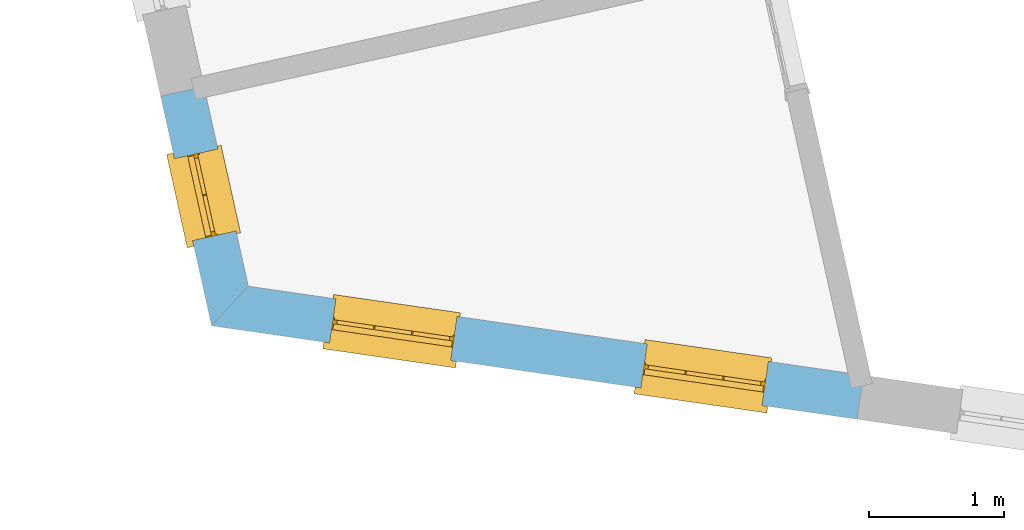
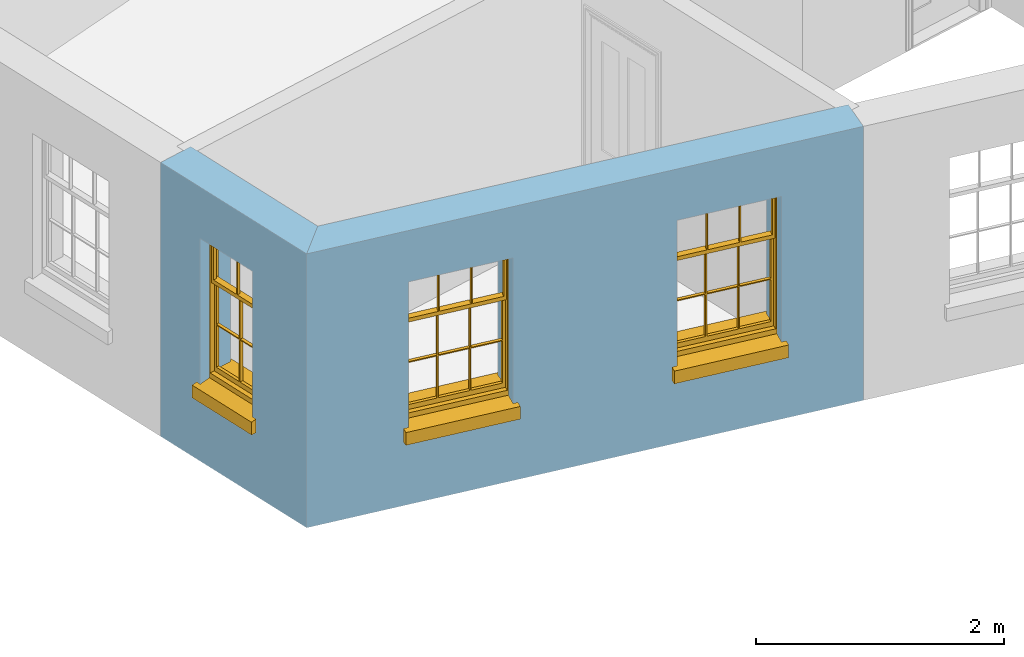
# One storey, part 2 of 11: 3 windows, 3 openings, plus 2 elements that do not belong to this part.
"""IFC2X3 building model written with IfcOpenShell, lengths in metres."""

from ifc_helpers import new_model, si_unit, frame, origin, place, context, subcontext, project, spatial, polyline, outline, extrude, faceted_brep, material, layer, layer_set, layer_usage, element, fill, save


model = new_model("IFC2X3")

# Units and contexts
model_context = context("Model", 3, world=origin())
body_context = subcontext(model_context, "Body", "Model", "MODEL_VIEW")
ifc_project = project(units=[si_unit("PLANEANGLEUNIT", "RADIAN"), si_unit("MASSUNIT", "GRAM", prefix="KILO"), si_unit("FORCEUNIT", "NEWTON", prefix="KILO"), si_unit("LENGTHUNIT", "METRE")], contexts=[model_context])

# Site, building, storey
site_placement = place(None, origin())
site = spatial("IfcSite", under=ifc_project, at=site_placement, CompositionType="ELEMENT")
building_placement = place(None, origin())
building = spatial("IfcBuilding", under=site, at=building_placement, Name="Building plot-16", CompositionType="ELEMENT")
storey_placement = place(None, frame((0.0, 0.0, 9.0)))
storey = spatial("IfcBuildingStorey", under=building, at=storey_placement, Name="Floor 2", CompositionType="ELEMENT", Elevation=9.0)

# Wall, opening, window
ifc_material = material(Name="Masonry")
ifc_layer = layer(ifc_material, 0.33, ventilated=False)
ifc_layer_set = layer_set([ifc_layer], Name="My Wall")
ifc_layer_usage = layer_usage(ifc_layer_set, "AXIS2", "NEGATIVE", 0.08)
wall_1_placement = place(storey_placement, origin())
wall_1 = element("IfcWallStandardCase", 1, at=wall_1_placement, inside=storey, material=ifc_layer_usage, Name="exterior", context=body_context, shape_type="SweptSolid", body=[
    extrude(outline(polyline([(87.6197813226672, 33.5557428221092), (87.2976082317312, 33.4842970421306), (87.6756142911979, 31.7797403754188), (87.9484434240576, 32.0736946856034), (87.6197813226672, 33.5557428221092)])), origin(), (0.0, 0.0, 1.0), 2.7),
])
opening_1_placement = place(storey_placement, frame((0.0, 0.0, 0.75)))
opening_1 = element("IfcOpeningElement", 2, at=opening_1_placement, cuts=wall_1, Name="Opening", ObjectType="Opening", context=body_context, shape_type="SweptSolid", body=[
    extrude(outline(polyline([(87.4002633796378, 33.0213903972391), (87.5355773568699, 32.4112140886482), (87.8577504478059, 32.4826598686268), (87.7224364705738, 33.0928361772177), (87.4002633796378, 33.0213903972391)])), origin(), (0.0, 0.0, 1.0), 1.445),
])
window_1_placement = place(storey_placement, frame((87.6443339030741, 33.075515988132, 0.75), z_axis=(0.0, 0.0, 1.0), x_axis=(0.135313977232144, -0.610176308590908, 0.0)))
window_1 = element("IfcWindow", 3, at=window_1_placement, inside=storey, Name="toilet outside window", OverallHeight=1.445, OverallWidth=0.625, context=body_context, shape_type="Brep", held_by="IfcProductRepresentation", body=[
    faceted_brep([(0.591875, -0.105, 0.999097), (0.591875, -0.105, 1.411875), (0.615, -0.105, 1.435), (0.033125, -0.105, 1.411875), (0.033125, -0.105, 0.999097), (0.01, -0.105, 1.435), (0.033125, -0.135, 1.411875), (0.01, -0.135, 1.435), (0.033125, -0.135, 0.999097), (0.591875, -0.135, 1.411875), (0.591875, -0.135, 0.999097), (0.615, -0.135, 1.435), (0.033125, -0.105, 0.960972), (0.01, -0.105, 0.960972), (0.033125, -0.105, 0.548195), (0.591875, -0.105, 0.960972), (0.591875, -0.105, 0.548195), (0.615, -0.105, 0.960972), (0.591875, -0.105, 0.538195), (0.591875, -0.105, 0.125417), (0.615, -0.105, 0.077167), (0.033125, -0.105, 0.125417), (0.033125, -0.105, 0.538195), (0.01, -0.105, 0.077167), (0.615, -0.135, 0.960972), (0.01, -0.135, 0.960972), (-0.0425, -0.25, 0.01), (-0.0425, -0.3, 0.001667), (0.0, -0.25, 0.01), (0.6675, -0.25, 0.01), (0.625, -0.25, 0.01), (0.6675, -0.3, 0.001667), (-0.02, 0.08, 0.077167), (0.0, 0.08, 0.077167), (-0.02, 0.11, 0.077167), (0.0, -0.06, 0.077167), (0.01, -0.06, 0.077167), (0.625, -0.06, 0.077167), (0.625, 0.08, 0.077167), (0.615, -0.06, 0.077167), (0.645, 0.08, 0.077167), (0.645, 0.11, 0.077167), (0.01, -0.105, 0.999097), (0.01, -0.075, 0.999097), (0.615, -0.105, 0.999097), (0.615, -0.075, 0.999097), (0.591875, -0.075, 0.125417), (0.591875, -0.075, 0.538195), (0.615, -0.075, 0.077167), (0.591875, -0.075, 0.548195), (0.591875, -0.075, 0.960972), (0.033125, -0.075, 0.125417), (0.01, -0.075, 0.077167), (0.033125, -0.075, 0.538195), (0.033125, -0.075, 0.960972), (0.033125, -0.075, 0.548195), (-0.02, 0.08, 0.052167), (-0.02, 0.11, 0.052167), (0.645, 0.11, 0.052167), (0.645, 0.08, 0.052167), (0.625, 0.08, 0.052167), (0.0, 0.08, 0.052167), (0.625, -0.15, 0.026667), (0.0, -0.15, 0.026667), (-0.0425, -0.3, -0.123333), (0.6675, -0.3, -0.123333), (-0.0425, -0.25, -0.123333), (0.6675, -0.25, -0.123333), (0.01, -0.06, 1.435), (0.615, -0.06, 1.435), (0.0, -0.06, 1.445), (0.625, -0.06, 1.445), (0.01, -0.15, 0.077167), (0.615, -0.15, 0.077167), (0.3175, -0.075, 0.548195), (0.3175, -0.105, 0.548195), (0.3175, -0.075, 0.538195), (0.3175, -0.075, 0.125417), (0.3075, -0.075, 0.125417), (0.3075, -0.075, 0.538195), (0.3075, -0.075, 0.548195), (0.3175, -0.075, 0.960972), (0.3075, -0.075, 0.960972), (0.3075, -0.105, 0.538195), (0.3075, -0.105, 0.125417), (0.3175, -0.105, 0.125417), (0.3175, -0.105, 0.538195), (0.3075, -0.105, 0.548195), (0.3075, -0.105, 0.960972), (0.3175, -0.105, 0.960972), (0.3175, -0.135, 1.411875), (0.3075, -0.135, 1.411875), (0.3075, -0.135, 0.999097), (0.3175, -0.135, 0.999097), (0.3175, -0.105, 0.999097), (0.3075, -0.105, 0.999097), (0.3075, -0.105, 1.411875), (0.3175, -0.105, 1.411875), (0.625, -0.15, 1.445), (0.615, -0.15, 1.435), (0.01, -0.15, 1.435), (0.0, -0.15, 1.445), (0.625, -0.25, 0.0), (0.0, -0.25, 0.0), (0.625, 0.08, 0.0), (0.0, 0.08, 0.0)], [[[0, 1, 2]], [[3, 4, 5]], [[6, 7, 8]], [[9, 10, 11]], [[12, 13, 14]], [[15, 16, 17]], [[18, 19, 20]], [[21, 22, 23]], [[24, 15, 17]], [[13, 12, 25]], [[26, 27, 28]], [[29, 30, 31]], [[32, 33, 34]], [[35, 36, 33]], [[37, 38, 39]], [[40, 41, 38]], [[42, 4, 43]], [[44, 45, 0]], [[46, 47, 48]], [[49, 50, 45]], [[51, 52, 53]], [[54, 55, 43]], [[38, 33, 36, 39]], [[41, 34, 33, 38]], [[56, 32, 34, 57]], [[57, 34, 41, 58]], [[58, 41, 40, 59]], [[57, 58, 60, 61]], [[52, 48, 39, 36]], [[62, 63, 28, 30]], [[27, 31, 30, 28]], [[27, 64, 65, 31]], [[66, 67, 65, 64]], [[2, 5, 68, 69]], [[68, 70, 71, 69]], [[20, 23, 72, 73]], [[73, 72, 63, 62]], [[16, 49, 74, 75]], [[76, 77, 78, 79]], [[80, 79, 53, 55]], [[81, 74, 80, 82]], [[76, 74, 49, 47]], [[83, 79, 78, 84]], [[22, 53, 79, 83]], [[85, 77, 76, 86]], [[87, 80, 55, 14]], [[88, 82, 80, 87]], [[75, 74, 81, 89]], [[86, 76, 47, 18]], [[86, 18, 16, 75]], [[86, 83, 84, 85]], [[87, 14, 22, 83]], [[89, 88, 87, 75]], [[90, 91, 92, 93]], [[94, 95, 96, 97]], [[91, 96, 95, 92]], [[93, 94, 97, 90]], [[74, 76, 79, 80]], [[75, 87, 83, 86]], [[84, 78, 51, 21]], [[6, 3, 96, 91]], [[90, 97, 1, 9]], [[19, 46, 77, 85]], [[26, 66, 64, 27]], [[29, 31, 65, 67]], [[25, 24, 93, 92]], [[11, 7, 91, 90]], [[77, 48, 52, 78]], [[43, 45, 81, 82]], [[45, 43, 95, 94]], [[5, 2, 97, 96]], [[24, 25, 88, 89]], [[42, 5, 4]], [[2, 44, 0]], [[49, 45, 48, 47]], [[52, 43, 55, 53]], [[14, 13, 23, 22]], [[20, 17, 16, 18]], [[24, 11, 10]], [[25, 8, 7]], [[8, 4, 3, 6]], [[9, 1, 0, 10]], [[15, 50, 49, 16]], [[18, 47, 46, 19]], [[21, 51, 53, 22]], [[14, 55, 54, 12]], [[44, 2, 69, 45]], [[68, 5, 42, 43]], [[36, 35, 70, 68]], [[39, 69, 71, 37]], [[62, 98, 99, 73]], [[63, 72, 100, 101]], [[8, 92, 95, 4]], [[93, 10, 0, 94]], [[82, 88, 12, 54]], [[17, 20, 73, 24]], [[72, 23, 13, 25]], [[52, 36, 68, 43]], [[69, 39, 48, 45]], [[11, 24, 73, 99]], [[7, 100, 72, 25]], [[84, 21, 23]], [[20, 19, 85]], [[20, 85, 84, 23]], [[24, 10, 93]], [[92, 8, 25]], [[90, 9, 11]], [[7, 6, 91]], [[96, 3, 5]], [[2, 1, 97]], [[11, 99, 100, 7]], [[98, 101, 100, 99]], [[82, 54, 43]], [[50, 81, 45]], [[15, 89, 81, 50]], [[77, 46, 48]], [[52, 51, 78]], [[89, 15, 24]], [[25, 12, 88]], [[43, 4, 95]], [[94, 0, 45]], [[71, 70, 101, 98]], [[70, 35, 63, 101]], [[98, 62, 37, 71]], [[102, 67, 66, 103]], [[60, 58, 59]], [[38, 60, 59, 40]], [[61, 56, 57]], [[32, 56, 61, 33]], [[61, 60, 104, 105]], [[62, 60, 38, 37]], [[102, 104, 60, 62]], [[33, 61, 63, 35]], [[61, 105, 103, 63]], [[104, 102, 103, 105]], [[28, 103, 66, 26]], [[63, 103, 28]], [[29, 67, 102, 30]], [[30, 102, 62]]]),
])
fill(opening_1, window_1)

# Wall, openings, windows
wall_2_placement = place(storey_placement, origin())
wall_2 = element("IfcWallStandardCase", 4, at=wall_2_placement, inside=storey, material=ifc_layer_usage, Name="exterior", context=body_context, shape_type="SweptSolid", body=[
    extrude(outline(polyline([(87.9484434240576, 32.0736946856034), (87.6756142911979, 31.7797403754188), (92.4666954104416, 31.086381689099), (92.513960177979, 31.4129793647637), (87.9484434240576, 32.0736946856034)])), origin(), (0.0, 0.0, 1.0), 2.7),
])
opening_2_placement = place(storey_placement, frame((0.0, 0.0, 0.75)))
opening_2 = element("IfcOpeningElement", 5, at=opening_2_placement, cuts=wall_2, Name="Opening", ObjectType="Opening", context=body_context, shape_type="SweptSolid", body=[
    extrude(outline(polyline([(88.5512372257678, 31.653021425663), (89.4518550586615, 31.5226852485144), (89.4991198261989, 31.8492829241791), (88.5985019933052, 31.9796191013278), (88.5512372257678, 31.653021425663)])), origin(), (0.0, 0.0, 1.0), 1.445),
])
opening_3_placement = place(storey_placement, frame((0.0, 0.0, 0.75)))
opening_3 = element("IfcOpeningElement", 6, at=opening_3_placement, cuts=wall_2, Name="Opening", ObjectType="Opening", context=body_context, shape_type="SweptSolid", body=[
    extrude(outline(polyline([(90.861336737919, 31.3187069936699), (91.7619545708128, 31.1883708165212), (91.8092193383502, 31.514968492186), (90.9086015054565, 31.6453046693347), (90.861336737919, 31.3187069936699)])), origin(), (0.0, 0.0, 1.0), 1.445),
])
window_2_placement = place(storey_placement, frame((88.5870438678416, 31.9004439072273, 0.75), z_axis=(0.0, 0.0, 1.0), x_axis=(0.900617832893758, -0.130336177148656, 0.0)))
window_2 = element("IfcWindow", 7, at=window_2_placement, inside=storey, Name="toilet outside window", OverallHeight=1.445, OverallWidth=0.91, context=body_context, shape_type="Brep", held_by="IfcProductRepresentation", body=[
    faceted_brep([(0.876875, -0.105, 0.999097), (0.876875, -0.105, 1.411875), (0.9, -0.105, 1.435), (0.033125, -0.105, 1.411875), (0.033125, -0.105, 0.999097), (0.01, -0.105, 1.435), (0.033125, -0.135, 1.411875), (0.01, -0.135, 1.435), (0.033125, -0.135, 0.999097), (0.876875, -0.135, 1.411875), (0.876875, -0.135, 0.999097), (0.9, -0.135, 1.435), (0.033125, -0.105, 0.960972), (0.01, -0.105, 0.960972), (0.033125, -0.105, 0.548195), (0.876875, -0.105, 0.960972), (0.876875, -0.105, 0.548195), (0.9, -0.105, 0.960972), (0.876875, -0.105, 0.538195), (0.876875, -0.105, 0.125417), (0.9, -0.105, 0.077167), (0.033125, -0.105, 0.125417), (0.033125, -0.105, 0.538195), (0.01, -0.105, 0.077167), (0.9, -0.135, 0.960972), (0.01, -0.135, 0.960972), (-0.0425, -0.25, 0.01), (-0.0425, -0.3, 0.001667), (0.0, -0.25, 0.01), (0.9525, -0.25, 0.01), (0.91, -0.25, 0.01), (0.9525, -0.3, 0.001667), (-0.02, 0.08, 0.077167), (0.0, 0.08, 0.077167), (-0.02, 0.11, 0.077167), (0.0, -0.06, 0.077167), (0.01, -0.06, 0.077167), (0.91, -0.06, 0.077167), (0.91, 0.08, 0.077167), (0.9, -0.06, 0.077167), (0.93, 0.08, 0.077167), (0.93, 0.11, 0.077167), (0.01, -0.105, 0.999097), (0.01, -0.075, 0.999097), (0.9, -0.105, 0.999097), (0.9, -0.075, 0.999097), (0.876875, -0.075, 0.125417), (0.876875, -0.075, 0.538195), (0.9, -0.075, 0.077167), (0.876875, -0.075, 0.548195), (0.876875, -0.075, 0.960972), (0.033125, -0.075, 0.125417), (0.01, -0.075, 0.077167), (0.033125, -0.075, 0.538195), (0.033125, -0.075, 0.960972), (0.033125, -0.075, 0.548195), (-0.02, 0.08, 0.052167), (-0.02, 0.11, 0.052167), (0.93, 0.11, 0.052167), (0.93, 0.08, 0.052167), (0.91, 0.08, 0.052167), (0.0, 0.08, 0.052167), (0.91, -0.15, 0.026667), (0.0, -0.15, 0.026667), (-0.0425, -0.3, -0.123333), (0.9525, -0.3, -0.123333), (-0.0425, -0.25, -0.123333), (0.9525, -0.25, -0.123333), (0.01, -0.06, 1.435), (0.9, -0.06, 1.435), (0.0, -0.06, 1.445), (0.91, -0.06, 1.445), (0.01, -0.15, 0.077167), (0.9, -0.15, 0.077167), (0.592292, -0.105, 0.125417), (0.592292, -0.075, 0.125417), (0.317708, -0.075, 0.125417), (0.317708, -0.105, 0.125417), (0.592292, -0.105, 0.548195), (0.317708, -0.105, 0.548195), (0.317708, -0.105, 0.538195), (0.592292, -0.105, 0.538195), (0.592292, -0.075, 0.548195), (0.317708, -0.075, 0.548195), (0.602292, -0.075, 0.548195), (0.602292, -0.105, 0.548195), (0.317708, -0.075, 0.538195), (0.307708, -0.075, 0.125417), (0.307708, -0.075, 0.538195), (0.602292, -0.075, 0.538195), (0.602292, -0.075, 0.125417), (0.592292, -0.075, 0.538195), (0.307708, -0.075, 0.548195), (0.317708, -0.075, 0.960972), (0.307708, -0.075, 0.960972), (0.602292, -0.075, 0.960972), (0.592292, -0.075, 0.960972), (0.307708, -0.105, 0.538195), (0.307708, -0.105, 0.125417), (0.307708, -0.105, 0.548195), (0.307708, -0.105, 0.960972), (0.592292, -0.105, 0.960972), (0.317708, -0.105, 0.960972), (0.602292, -0.105, 0.960972), (0.602292, -0.105, 0.538195), (0.602292, -0.105, 0.125417), (0.317708, -0.135, 1.411875), (0.307708, -0.135, 1.411875), (0.307708, -0.135, 0.999097), (0.317708, -0.135, 0.999097), (0.602292, -0.135, 1.411875), (0.592292, -0.135, 1.411875), (0.592292, -0.135, 0.999097), (0.602292, -0.135, 0.999097), (0.317708, -0.105, 0.999097), (0.307708, -0.105, 0.999097), (0.307708, -0.105, 1.411875), (0.317708, -0.105, 1.411875), (0.602292, -0.105, 0.999097), (0.592292, -0.105, 0.999097), (0.592292, -0.105, 1.411875), (0.602292, -0.105, 1.411875), (0.91, -0.15, 1.445), (0.9, -0.15, 1.435), (0.01, -0.15, 1.435), (0.0, -0.15, 1.445), (0.91, -0.25, 0.0), (0.0, -0.25, 0.0), (0.91, 0.08, 0.0), (0.0, 0.08, 0.0)], [[[0, 1, 2]], [[3, 4, 5]], [[6, 7, 8]], [[9, 10, 11]], [[12, 13, 14]], [[15, 16, 17]], [[18, 19, 20]], [[21, 22, 23]], [[24, 15, 17]], [[13, 12, 25]], [[26, 27, 28]], [[29, 30, 31]], [[32, 33, 34]], [[35, 36, 33]], [[37, 38, 39]], [[40, 41, 38]], [[42, 4, 43]], [[44, 45, 0]], [[46, 47, 48]], [[49, 50, 45]], [[51, 52, 53]], [[54, 55, 43]], [[38, 33, 36, 39]], [[41, 34, 33, 38]], [[56, 32, 34, 57]], [[57, 34, 41, 58]], [[58, 41, 40, 59]], [[57, 58, 60, 61]], [[52, 48, 39, 36]], [[62, 63, 28, 30]], [[27, 31, 30, 28]], [[27, 64, 65, 31]], [[66, 67, 65, 64]], [[2, 5, 68, 69]], [[68, 70, 71, 69]], [[20, 23, 72, 73]], [[73, 72, 63, 62]], [[74, 75, 76, 77]], [[78, 79, 80, 81]], [[78, 82, 83, 79]], [[16, 49, 84, 85]], [[86, 76, 87, 88]], [[89, 90, 75, 91]], [[92, 88, 53, 55]], [[82, 91, 86, 83]], [[93, 83, 92, 94]], [[95, 84, 82, 96]], [[89, 84, 49, 47]], [[97, 88, 87, 98]], [[22, 53, 88, 97]], [[81, 91, 75, 74]], [[80, 86, 91, 81]], [[77, 76, 86, 80]], [[99, 92, 55, 14]], [[100, 94, 92, 99]], [[101, 96, 82, 78]], [[79, 83, 93, 102]], [[85, 84, 95, 103]], [[104, 89, 47, 18]], [[105, 90, 89, 104]], [[104, 18, 16, 85]], [[80, 97, 98, 77]], [[104, 81, 74, 105]], [[103, 101, 78, 85]], [[99, 14, 22, 97]], [[102, 100, 99, 79]], [[106, 107, 108, 109]], [[110, 111, 112, 113]], [[114, 115, 116, 117]], [[118, 119, 120, 121]], [[107, 116, 115, 108]], [[111, 120, 119, 112]], [[109, 114, 117, 106]], [[113, 118, 121, 110]], [[85, 78, 81, 104]], [[84, 89, 91, 82]], [[83, 86, 88, 92]], [[79, 99, 97, 80]], [[109, 112, 119, 114]], [[102, 93, 96, 101]], [[106, 117, 120, 111]], [[98, 87, 51, 21]], [[6, 3, 116, 107]], [[110, 121, 1, 9]], [[19, 46, 90, 105]], [[26, 66, 64, 27]], [[29, 31, 65, 67]], [[25, 24, 112, 109]], [[11, 7, 106, 111]], [[75, 48, 52, 76]], [[43, 45, 96, 93]], [[45, 43, 114, 119]], [[5, 2, 120, 117]], [[24, 25, 102, 101]], [[42, 5, 4]], [[2, 44, 0]], [[49, 45, 48, 47]], [[52, 43, 55, 53]], [[14, 13, 23, 22]], [[20, 17, 16, 18]], [[24, 11, 10]], [[25, 8, 7]], [[8, 4, 3, 6]], [[9, 1, 0, 10]], [[15, 50, 49, 16]], [[18, 47, 46, 19]], [[21, 51, 53, 22]], [[14, 55, 54, 12]], [[44, 2, 69, 45]], [[68, 5, 42, 43]], [[36, 35, 70, 68]], [[39, 69, 71, 37]], [[62, 122, 123, 73]], [[63, 72, 124, 125]], [[8, 108, 115, 4]], [[113, 10, 0, 118]], [[94, 100, 12, 54]], [[17, 20, 73, 24]], [[72, 23, 13, 25]], [[52, 36, 68, 43]], [[69, 39, 48, 45]], [[11, 24, 73, 123]], [[7, 124, 72, 25]], [[23, 77, 98]], [[98, 21, 23]], [[105, 74, 20]], [[20, 19, 105]], [[20, 74, 77, 23]], [[113, 112, 24]], [[24, 10, 113]], [[25, 109, 108]], [[108, 8, 25]], [[110, 9, 11]], [[11, 111, 110]], [[7, 6, 107]], [[107, 106, 7]], [[5, 117, 116]], [[116, 3, 5]], [[121, 120, 2]], [[2, 1, 121]], [[11, 123, 124, 7]], [[122, 125, 124, 123]], [[43, 93, 94]], [[94, 54, 43]], [[96, 45, 95]], [[50, 95, 45]], [[15, 103, 95, 50]], [[48, 75, 90]], [[90, 46, 48]], [[87, 76, 52]], [[52, 51, 87]], [[103, 15, 24]], [[24, 101, 103]], [[100, 102, 25]], [[25, 12, 100]], [[115, 114, 43]], [[43, 4, 115]], [[118, 0, 45]], [[45, 119, 118]], [[71, 70, 125, 122]], [[70, 35, 63, 125]], [[122, 62, 37, 71]], [[126, 67, 66, 127]], [[60, 58, 59]], [[38, 60, 59, 40]], [[61, 56, 57]], [[32, 56, 61, 33]], [[61, 60, 128, 129]], [[62, 60, 38, 37]], [[126, 128, 60, 62]], [[33, 61, 63, 35]], [[61, 129, 127, 63]], [[128, 126, 127, 129]], [[28, 127, 66, 26]], [[63, 127, 28]], [[29, 67, 126, 30]], [[30, 126, 62]]]),
])
fill(opening_2, window_2)
window_3_placement = place(storey_placement, frame((90.8971433799929, 31.5661294752341, 0.75), z_axis=(0.0, 0.0, 1.0), x_axis=(0.900617832893772, -0.130336177148656, 0.0)))
window_3 = element("IfcWindow", 8, at=window_3_placement, inside=storey, Name="toilet outside window", OverallHeight=1.445, OverallWidth=0.91, context=body_context, shape_type="Brep", held_by="IfcProductRepresentation", body=[
    faceted_brep([(0.876875, -0.105, 0.999097), (0.876875, -0.105, 1.411875), (0.9, -0.105, 1.435), (0.033125, -0.105, 1.411875), (0.033125, -0.105, 0.999097), (0.01, -0.105, 1.435), (0.033125, -0.135, 1.411875), (0.01, -0.135, 1.435), (0.033125, -0.135, 0.999097), (0.876875, -0.135, 1.411875), (0.876875, -0.135, 0.999097), (0.9, -0.135, 1.435), (0.033125, -0.105, 0.960972), (0.01, -0.105, 0.960972), (0.033125, -0.105, 0.548195), (0.876875, -0.105, 0.960972), (0.876875, -0.105, 0.548195), (0.9, -0.105, 0.960972), (0.876875, -0.105, 0.538195), (0.876875, -0.105, 0.125417), (0.9, -0.105, 0.077167), (0.033125, -0.105, 0.125417), (0.033125, -0.105, 0.538195), (0.01, -0.105, 0.077167), (0.9, -0.135, 0.960972), (0.01, -0.135, 0.960972), (-0.0425, -0.25, 0.01), (-0.0425, -0.3, 0.001667), (0.0, -0.25, 0.01), (0.9525, -0.25, 0.01), (0.91, -0.25, 0.01), (0.9525, -0.3, 0.001667), (-0.02, 0.08, 0.077167), (0.0, 0.08, 0.077167), (-0.02, 0.11, 0.077167), (0.0, -0.06, 0.077167), (0.01, -0.06, 0.077167), (0.91, -0.06, 0.077167), (0.91, 0.08, 0.077167), (0.9, -0.06, 0.077167), (0.93, 0.08, 0.077167), (0.93, 0.11, 0.077167), (0.01, -0.105, 0.999097), (0.01, -0.075, 0.999097), (0.9, -0.105, 0.999097), (0.9, -0.075, 0.999097), (0.876875, -0.075, 0.125417), (0.876875, -0.075, 0.538195), (0.9, -0.075, 0.077167), (0.876875, -0.075, 0.548195), (0.876875, -0.075, 0.960972), (0.033125, -0.075, 0.125417), (0.01, -0.075, 0.077167), (0.033125, -0.075, 0.538195), (0.033125, -0.075, 0.960972), (0.033125, -0.075, 0.548195), (-0.02, 0.08, 0.052167), (-0.02, 0.11, 0.052167), (0.93, 0.11, 0.052167), (0.93, 0.08, 0.052167), (0.91, 0.08, 0.052167), (0.0, 0.08, 0.052167), (0.91, -0.15, 0.026667), (0.0, -0.15, 0.026667), (-0.0425, -0.3, -0.123333), (0.9525, -0.3, -0.123333), (-0.0425, -0.25, -0.123333), (0.9525, -0.25, -0.123333), (0.01, -0.06, 1.435), (0.9, -0.06, 1.435), (0.0, -0.06, 1.445), (0.91, -0.06, 1.445), (0.01, -0.15, 0.077167), (0.9, -0.15, 0.077167), (0.592292, -0.105, 0.125417), (0.592292, -0.075, 0.125417), (0.317708, -0.075, 0.125417), (0.317708, -0.105, 0.125417), (0.592292, -0.105, 0.548195), (0.317708, -0.105, 0.548195), (0.317708, -0.105, 0.538195), (0.592292, -0.105, 0.538195), (0.592292, -0.075, 0.548195), (0.317708, -0.075, 0.548195), (0.602292, -0.075, 0.548195), (0.602292, -0.105, 0.548195), (0.317708, -0.075, 0.538195), (0.307708, -0.075, 0.125417), (0.307708, -0.075, 0.538195), (0.602292, -0.075, 0.538195), (0.602292, -0.075, 0.125417), (0.592292, -0.075, 0.538195), (0.307708, -0.075, 0.548195), (0.317708, -0.075, 0.960972), (0.307708, -0.075, 0.960972), (0.602292, -0.075, 0.960972), (0.592292, -0.075, 0.960972), (0.307708, -0.105, 0.538195), (0.307708, -0.105, 0.125417), (0.307708, -0.105, 0.548195), (0.307708, -0.105, 0.960972), (0.592292, -0.105, 0.960972), (0.317708, -0.105, 0.960972), (0.602292, -0.105, 0.960972), (0.602292, -0.105, 0.538195), (0.602292, -0.105, 0.125417), (0.317708, -0.135, 1.411875), (0.307708, -0.135, 1.411875), (0.307708, -0.135, 0.999097), (0.317708, -0.135, 0.999097), (0.602292, -0.135, 1.411875), (0.592292, -0.135, 1.411875), (0.592292, -0.135, 0.999097), (0.602292, -0.135, 0.999097), (0.317708, -0.105, 0.999097), (0.307708, -0.105, 0.999097), (0.307708, -0.105, 1.411875), (0.317708, -0.105, 1.411875), (0.602292, -0.105, 0.999097), (0.592292, -0.105, 0.999097), (0.592292, -0.105, 1.411875), (0.602292, -0.105, 1.411875), (0.91, -0.15, 1.445), (0.9, -0.15, 1.435), (0.01, -0.15, 1.435), (0.0, -0.15, 1.445), (0.91, -0.25, 0.0), (0.0, -0.25, 0.0), (0.91, 0.08, 0.0), (0.0, 0.08, 0.0)], [[[0, 1, 2]], [[3, 4, 5]], [[6, 7, 8]], [[9, 10, 11]], [[12, 13, 14]], [[15, 16, 17]], [[18, 19, 20]], [[21, 22, 23]], [[24, 15, 17]], [[13, 12, 25]], [[26, 27, 28]], [[29, 30, 31]], [[32, 33, 34]], [[35, 36, 33]], [[37, 38, 39]], [[40, 41, 38]], [[42, 4, 43]], [[44, 45, 0]], [[46, 47, 48]], [[49, 50, 45]], [[51, 52, 53]], [[54, 55, 43]], [[38, 33, 36, 39]], [[41, 34, 33, 38]], [[56, 32, 34, 57]], [[57, 34, 41, 58]], [[58, 41, 40, 59]], [[57, 58, 60, 61]], [[52, 48, 39, 36]], [[62, 63, 28, 30]], [[27, 31, 30, 28]], [[27, 64, 65, 31]], [[66, 67, 65, 64]], [[2, 5, 68, 69]], [[68, 70, 71, 69]], [[20, 23, 72, 73]], [[73, 72, 63, 62]], [[74, 75, 76, 77]], [[78, 79, 80, 81]], [[78, 82, 83, 79]], [[16, 49, 84, 85]], [[86, 76, 87, 88]], [[89, 90, 75, 91]], [[92, 88, 53, 55]], [[82, 91, 86, 83]], [[93, 83, 92, 94]], [[95, 84, 82, 96]], [[89, 84, 49, 47]], [[97, 88, 87, 98]], [[22, 53, 88, 97]], [[81, 91, 75, 74]], [[80, 86, 91, 81]], [[77, 76, 86, 80]], [[99, 92, 55, 14]], [[100, 94, 92, 99]], [[101, 96, 82, 78]], [[79, 83, 93, 102]], [[85, 84, 95, 103]], [[104, 89, 47, 18]], [[105, 90, 89, 104]], [[104, 18, 16, 85]], [[80, 97, 98, 77]], [[104, 81, 74, 105]], [[103, 101, 78, 85]], [[99, 14, 22, 97]], [[102, 100, 99, 79]], [[106, 107, 108, 109]], [[110, 111, 112, 113]], [[114, 115, 116, 117]], [[118, 119, 120, 121]], [[107, 116, 115, 108]], [[111, 120, 119, 112]], [[109, 114, 117, 106]], [[113, 118, 121, 110]], [[85, 78, 81, 104]], [[84, 89, 91, 82]], [[83, 86, 88, 92]], [[79, 99, 97, 80]], [[109, 112, 119, 114]], [[102, 93, 96, 101]], [[106, 117, 120, 111]], [[98, 87, 51, 21]], [[6, 3, 116, 107]], [[110, 121, 1, 9]], [[19, 46, 90, 105]], [[26, 66, 64, 27]], [[29, 31, 65, 67]], [[25, 24, 112, 109]], [[11, 7, 106, 111]], [[75, 48, 52, 76]], [[43, 45, 96, 93]], [[45, 43, 114, 119]], [[5, 2, 120, 117]], [[24, 25, 102, 101]], [[42, 5, 4]], [[2, 44, 0]], [[49, 45, 48, 47]], [[52, 43, 55, 53]], [[14, 13, 23, 22]], [[20, 17, 16, 18]], [[24, 11, 10]], [[25, 8, 7]], [[8, 4, 3, 6]], [[9, 1, 0, 10]], [[15, 50, 49, 16]], [[18, 47, 46, 19]], [[21, 51, 53, 22]], [[14, 55, 54, 12]], [[44, 2, 69, 45]], [[68, 5, 42, 43]], [[36, 35, 70, 68]], [[39, 69, 71, 37]], [[62, 122, 123, 73]], [[63, 72, 124, 125]], [[8, 108, 115, 4]], [[113, 10, 0, 118]], [[94, 100, 12, 54]], [[17, 20, 73, 24]], [[72, 23, 13, 25]], [[52, 36, 68, 43]], [[69, 39, 48, 45]], [[11, 24, 73, 123]], [[7, 124, 72, 25]], [[23, 77, 98]], [[98, 21, 23]], [[105, 74, 20]], [[20, 19, 105]], [[20, 74, 77, 23]], [[113, 112, 24]], [[24, 10, 113]], [[25, 109, 108]], [[108, 8, 25]], [[110, 9, 11]], [[11, 111, 110]], [[7, 6, 107]], [[107, 106, 7]], [[5, 117, 116]], [[116, 3, 5]], [[121, 120, 2]], [[2, 1, 121]], [[11, 123, 124, 7]], [[122, 125, 124, 123]], [[43, 93, 94]], [[94, 54, 43]], [[96, 45, 95]], [[50, 95, 45]], [[15, 103, 95, 50]], [[48, 75, 90]], [[90, 46, 48]], [[87, 76, 52]], [[52, 51, 87]], [[103, 15, 24]], [[24, 101, 103]], [[100, 102, 25]], [[25, 12, 100]], [[115, 114, 43]], [[43, 4, 115]], [[118, 0, 45]], [[45, 119, 118]], [[71, 70, 125, 122]], [[70, 35, 63, 125]], [[122, 62, 37, 71]], [[126, 67, 66, 127]], [[60, 58, 59]], [[38, 60, 59, 40]], [[61, 56, 57]], [[32, 56, 61, 33]], [[61, 60, 128, 129]], [[62, 60, 38, 37]], [[126, 128, 60, 62]], [[33, 61, 63, 35]], [[61, 129, 127, 63]], [[128, 126, 127, 129]], [[28, 127, 66, 26]], [[63, 127, 28]], [[29, 67, 126, 30]], [[30, 126, 62]]]),
])
fill(opening_3, window_3)

save(model, "model.ifc")
